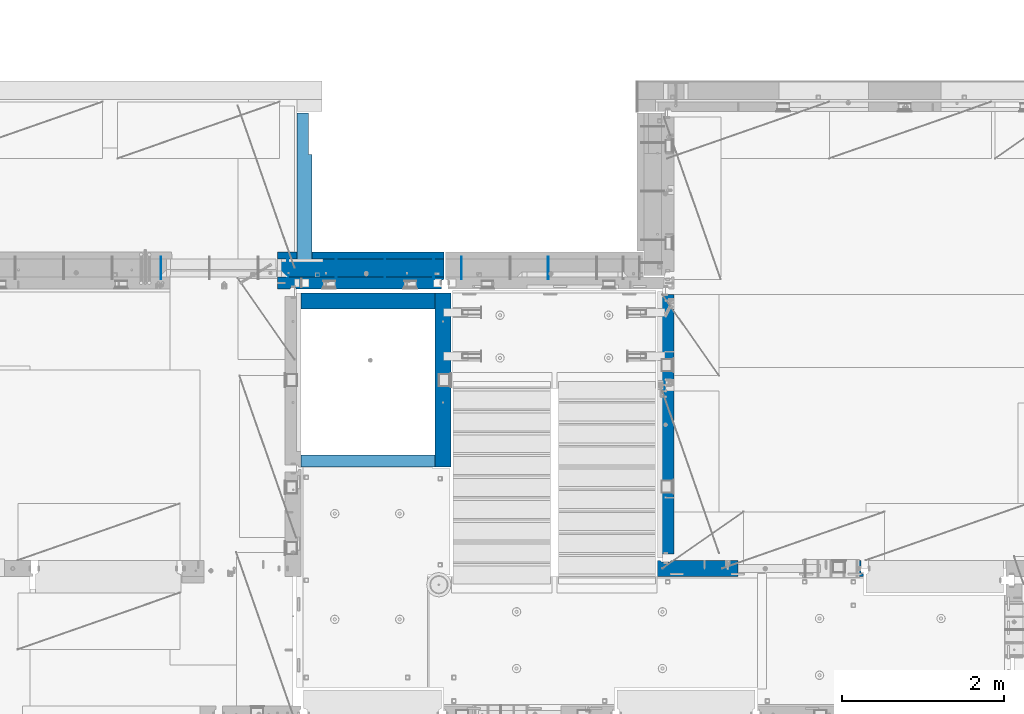
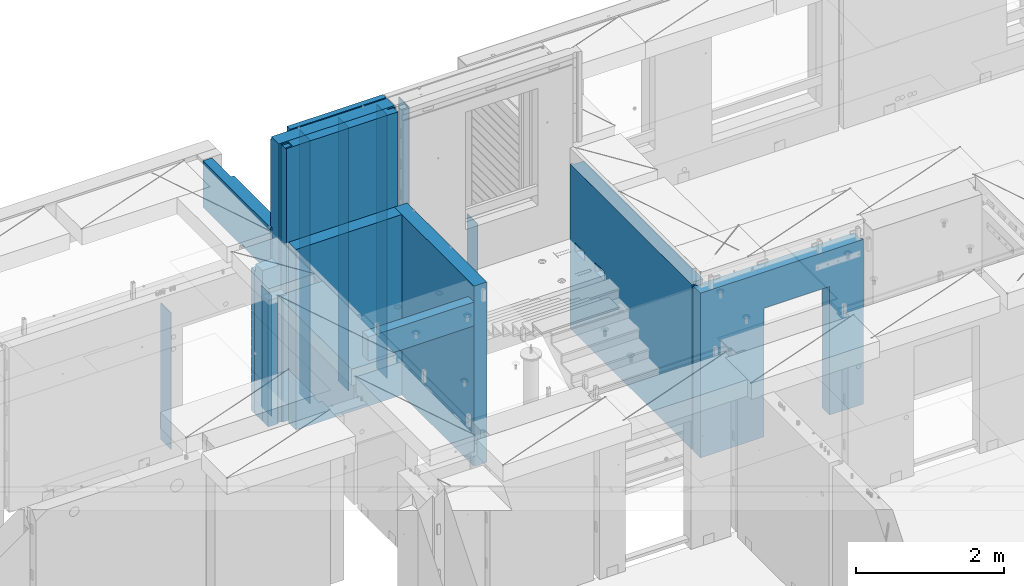
# One storey, part 217 of 325: 16 walls, 8 elements without a shape of their own.
"""IFC2X3 building model written with IfcOpenShell, lengths in millimetres."""

import ifcopenshell
import ifcopenshell.guid

model = None  # the IFC model being written
_history = None  # IfcOwnerHistory: only IFC2X3 demands one
_inside = {}  # id of a spatial element -> (the spatial element, [elements in it])
_under = {}  # id of a project, library or spatial element -> (it, [spatial elements below it])
_declared = {}  # id of a project -> (the project, [libraries it declares])
_typed = {}  # id of a type object -> (the type object, [elements of that type])
_made_of = {}  # id of a material, layer set ... -> (it, [elements and type objects made of it])


def new_model(schema):
    """Start an empty IFC model of exactly this schema.

    Asked for "IFC4X3", IfcOpenShell would pick the latest addendum, in which some entities
    have other attributes; the version numbers below select the first issue.
    IFC2X3 requires an IfcOwnerHistory on every rooted entity: one is made here for all.
    """
    global model, _history
    if schema == "IFC4X3":
        model = ifcopenshell.file(schema_version=(4, 3, 0, 0))
    else:
        model = ifcopenshell.file(schema=schema)
    _inside.clear()
    _under.clear()
    _declared.clear()
    _typed.clear()
    _made_of.clear()
    _history = None
    if model.schema == "IFC2X3":
        org = make("IfcOrganization", Name="unknown")
        user = make(
            "IfcPersonAndOrganization",
            ThePerson=make("IfcPerson", FamilyName="unknown"),
            TheOrganization=org,
        )
        app = make(
            "IfcApplication",
            ApplicationDeveloper=org,
            Version="unknown",
            ApplicationFullName="unknown",
            ApplicationIdentifier="unknown",
        )
        _history = make(
            "IfcOwnerHistory",
            OwningUser=user,
            OwningApplication=app,
            ChangeAction="ADDED",
            CreationDate=0,
        )
    return model


def make(cls, **values):
    """One entity of the class cls with the attributes given. An attribute that is None is left unset."""
    return model.create_entity(
        cls, **{name: value for name, value in values.items() if value is not None}
    )


def rooted(cls, **values):
    """An entity with a GlobalId (a new one), such as an element, a storey or a relation."""
    return make(cls, GlobalId=ifcopenshell.guid.new(), OwnerHistory=_history, **values)


def si_unit(unit_type, name, prefix=None):
    """IfcSIUnit, for example si_unit("LENGTHUNIT", "METRE", prefix="MILLI")."""
    return make("IfcSIUnit", UnitType=unit_type, Prefix=prefix, Name=name)


def assignment(units):
    """IfcUnitAssignment: the units of a project."""
    return None if units is None else make("IfcUnitAssignment", Units=units)


def point(xyz):
    """IfcCartesianPoint."""
    return None if xyz is None else make("IfcCartesianPoint", Coordinates=xyz)


def direction(xyz):
    """IfcDirection."""
    return None if xyz is None else make("IfcDirection", DirectionRatios=xyz)


def frame(location, z_axis=None, x_axis=None):
    """IfcAxis2Placement3D, a coordinate frame: its origin and axes. An axis left out is left unset."""
    return make(
        "IfcAxis2Placement3D",
        Location=point(location),
        Axis=direction(z_axis),
        RefDirection=direction(x_axis),
    )


def origin_with_axes():
    """The frame at (0, 0, 0) with the z axis (0, 0, 1) and the x axis (1, 0, 0) written out."""
    return frame((0.0, 0.0, 0.0), z_axis=(0.0, 0.0, 1.0), x_axis=(1.0, 0.0, 0.0))


def place(relative_to, where):
    """IfcLocalPlacement: puts the frame where relative to a parent placement (None: the world)."""
    return make(
        "IfcLocalPlacement", PlacementRelTo=relative_to, RelativePlacement=where
    )


def context(
    kind, dimensions, precision=None, world=None, true_north=None, identifier=None
):
    """IfcGeometricRepresentationContext, for example the 3D "Model" context."""
    return make(
        "IfcGeometricRepresentationContext",
        ContextIdentifier=identifier,
        ContextType=kind,
        CoordinateSpaceDimension=dimensions,
        Precision=precision,
        WorldCoordinateSystem=world,
        TrueNorth=true_north,
    )


def subcontext(parent, identifier, kind, view, scale=None):
    """IfcGeometricRepresentationSubContext, for example "Body" below "Model"."""
    return make(
        "IfcGeometricRepresentationSubContext",
        ContextIdentifier=identifier,
        ContextType=kind,
        ParentContext=parent,
        TargetScale=scale,
        TargetView=view,
    )


def project(units=None, contexts=None):
    """IfcProject with its units and contexts."""
    return rooted(
        "IfcProject",
        Name="project",
        RepresentationContexts=contexts,
        UnitsInContext=assignment(units),
    )


def spatial(cls, under=None, at=None, **own):
    """A site, building, storey or space (cls), placed at a placement, below another one or the project."""
    s = rooted(cls, ObjectPlacement=at, **own)
    if under is not None:
        _under.setdefault(under.id(), (under, []))[1].append(s)
    return s


def faces_of(points, faces, orient=None, outer=None):
    """IfcFace entities. A face is a list of loops; a loop is a list of indices into points, from 0.

    orient and outer hold one flag for each loop. By default every Orientation is true, the
    first loop of a face is its IfcFaceOuterBound and the others are IfcFaceBound.
    """
    made = []
    for i, loops in enumerate(faces):
        bounds = []
        for j, loop in enumerate(loops):
            is_outer = j == 0 if outer is None else outer[i][j]
            bounds.append(
                make(
                    "IfcFaceOuterBound" if is_outer else "IfcFaceBound",
                    Bound=make("IfcPolyLoop", Polygon=[points[k] for k in loop]),
                    Orientation=True if orient is None else orient[i][j],
                )
            )
        made.append(make("IfcFace", Bounds=bounds))
    return made


def faceted_brep(points, faces, orient=None, outer=None, voids=None):
    """IfcFacetedBrep: a solid bounded by flat faces; with voids (closed shells), ...WithVoids."""
    shared = [point(p) for p in points]
    hull = make("IfcClosedShell", CfsFaces=faces_of(shared, faces, orient, outer))
    if voids is None:
        return make("IfcFacetedBrep", Outer=hull)
    return make(
        "IfcFacetedBrepWithVoids",
        Outer=hull,
        Voids=[
            make(cls, CfsFaces=faces_of(shared, fs, o, b)) for cls, fs, o, b in voids
        ],
    )


def shape(context_of_items, identifier, shape_type, items):
    """IfcShapeRepresentation: the items that make up one representation, for example the "Body"."""
    return make(
        "IfcShapeRepresentation",
        ContextOfItems=context_of_items,
        RepresentationIdentifier=identifier,
        RepresentationType=shape_type,
        Items=items,
    )


def material(Name=None, Category=None):
    """IfcMaterial."""
    return make("IfcMaterial", Name=Name, Category=Category)


def made_of(thing, what):
    """Note that an element or type object is made of a material, layer set ...; save() writes the relation."""
    if what is not None:
        _made_of.setdefault(what.id(), (what, []))[1].append(thing)
    return thing


def type_object(cls, material=None, **own):
    """A type object (cls), such as IfcWallType, which elements share."""
    return made_of(rooted(cls, **own), material)


def element(
    cls,
    number,
    at=None,
    inside=None,
    cuts=None,
    type_object=None,
    material=None,
    context=None,
    identifier="Body",
    shape_type=None,
    held_by="IfcProductDefinitionShape",
    body=None,
    shapes=None,
    **own,
):
    """One element of the class cls, such as IfcWall. Its Tag is "e" and its number.

    at: its placement. inside: the storey or other place that contains it. cuts: it is an
    opening in that element (IfcRelVoidsElement). A single representation is given by context,
    identifier, shape_type and body (its items); several are given by shapes. held_by: the class
    of the entity that holds the representations. save() writes the other relations.
    """
    e = rooted(cls, Tag="e%d" % number, ObjectPlacement=at, **own)
    if body is not None:
        shapes = [shape(context, identifier, shape_type, body)]
    if shapes is not None:
        e.Representation = make(held_by, Representations=shapes)
    if inside is not None:
        _inside.setdefault(inside.id(), (inside, []))[1].append(e)
    if cuts is not None:
        rooted(
            "IfcRelVoidsElement", RelatingBuildingElement=cuts, RelatedOpeningElement=e
        )
    if type_object is not None:
        _typed.setdefault(type_object.id(), (type_object, []))[1].append(e)
    return made_of(e, material)


def aggregate(whole, parts):
    """IfcRelAggregates: a whole, such as a stair, and the parts it consists of."""
    return rooted("IfcRelAggregates", RelatingObject=whole, RelatedObjects=parts)


def save(model, path):
    """Write the relations noted so far, then the file.

    IfcRelAggregates (storeys below a building ...), IfcRelContainedInSpatialStructure (elements
    in a storey), IfcRelDefinesByType, IfcRelAssociatesMaterial and IfcRelDeclares: one each for
    every whole, place, type object, material and project.
    """
    for whole, parts in _under.values():
        aggregate(whole, parts)
    for where, things in _inside.values():
        rooted(
            "IfcRelContainedInSpatialStructure",
            RelatedElements=things,
            RelatingStructure=where,
        )
    for kind, things in _typed.values():
        rooted("IfcRelDefinesByType", RelatedObjects=things, RelatingType=kind)
    for what, things in _made_of.values():
        rooted("IfcRelAssociatesMaterial", RelatedObjects=things, RelatingMaterial=what)
    for by, libraries in _declared.values():
        rooted("IfcRelDeclares", RelatingContext=by, RelatedDefinitions=libraries)
    model.write(path)


model = new_model("IFC2X3")

# Units and contexts
model_context = context("Model", 3, precision=1e-05, world=origin_with_axes())
body_context = subcontext(model_context, "Body", "Model", "MODEL_VIEW")
ifc_project = project(units=[si_unit("LENGTHUNIT", "METRE", prefix="MILLI"), si_unit("AREAUNIT", "SQUARE_METRE"), si_unit("VOLUMEUNIT", "CUBIC_METRE"), si_unit("MASSUNIT", "GRAM", prefix="KILO"), si_unit("TIMEUNIT", "SECOND"), si_unit("PLANEANGLEUNIT", "RADIAN"), si_unit("SOLIDANGLEUNIT", "STERADIAN"), si_unit("THERMODYNAMICTEMPERATUREUNIT", "DEGREE_CELSIUS"), si_unit("LUMINOUSINTENSITYUNIT", "LUMEN")], contexts=[model_context])

# Site, building, storey
site_placement = place(None, origin_with_axes())
site = spatial("IfcSite", under=ifc_project, at=site_placement, CompositionType="ELEMENT")
building_placement = place(site_placement, origin_with_axes())
building = spatial("IfcBuilding", under=site, at=building_placement, CompositionType="ELEMENT")
storey_placement = place(building_placement, origin_with_axes())
storey = spatial("IfcBuildingStorey", under=building, at=storey_placement, Name="1", CompositionType="ELEMENT", Elevation=0.0)

# Assembly, wall
assembly_1_placement = place(storey_placement, origin_with_axes())
assembly_1 = element("IfcElementAssembly", 1, at=assembly_1_placement, inside=storey, AssemblyPlace="NOTDEFINED", PredefinedType="REINFORCEMENT_UNIT")
ifc_material_1 = material(Name="Undefined")
wall_type_1 = type_object("IfcWallType", PredefinedType="NOTDEFINED")
wall_1_placement = place(assembly_1_placement, frame((17645.0002441406, 20550.0, 82810.0), z_axis=(0.0, 0.0, 1.0), x_axis=(0.0, 1.0, 0.0)))
wall_1 = element("IfcWall", 2, at=wall_1_placement, type_object=wall_type_1, material=ifc_material_1, Name="(PD)", context=body_context, shape_type="Brep", body=[
    faceted_brep([(0.0, 5.0, -1000.0), (0.0, 5.0, 1000.0), (280.000000000011, 5.0, 1000.0), (280.000000000011, 5.0, -1000.0), (0.0, -5.0, 1000.0), (280.000000000011, -5.0, 1000.0), (0.0, -5.0, -1000.0), (280.000000000011, -5.0, -1000.0)], [[[0, 1, 2, 3]], [[1, 4, 5, 2]], [[4, 6, 7, 5]], [[6, 0, 3, 7]], [[5, 7, 3, 2]], [[6, 4, 1, 0]]]),
])

assembly_2_placement = place(storey_placement, origin_with_axes())
assembly_2 = element("IfcElementAssembly", 3, at=assembly_2_placement, inside=storey, AssemblyPlace="NOTDEFINED", PredefinedType="REINFORCEMENT_UNIT")
ifc_material_2 = material(Name="CONCRETE/C25/30")
wall_type_2 = type_object("IfcWallType", PredefinedType="NOTDEFINED")
wall_2_placement = place(assembly_2_placement, frame((22310.0, 16980.0, 83112.5), z_axis=(0.0, 0.0, 1.0), x_axis=(1.0, 0.0, 0.0)))
wall_2 = element("IfcWall", 4, at=wall_2_placement, type_object=wall_type_2, material=ifc_material_2, context=body_context, shape_type="Brep", body=[
    faceted_brep([(890.000686645508, 100.0, 762.5), (890.000686645508, -100.0, 762.5), (890.000686645508, -100.0, -1357.5), (890.000686645508, 100.0, -1357.5), (1910.00068664551, 100.0, 762.5), (1910.00068664551, -100.0, 762.5), (1910.00068664551, 100.0, -1357.5), (1910.00068664551, -100.0, -1357.5), (-100.0, -100.0, -1357.5), (-100.0, -100.0, 1357.5), (-100.0, 100.0, 1357.5), (-100.0, 100.0, -1357.5), (2440.0, -100.0, 1357.5), (2440.0, -100.0, -1357.5), (2440.0, -70.0000000000036, -1357.5), (2440.0, -70.0000000000036, 1357.5), (2410.0, 100.0, 1357.5), (2410.0, -57.0, 1357.5), (2410.0, -57.0, -1357.5), (2410.0, 100.0, -1357.5), (65.0000000000036, 100.0, 1357.5), (52.0, 80.0, 1357.5), (-52.0, 80.0, 1357.5), (-65.0, 100.0, 1357.5), (-65.0, 100.0, -1357.5), (-52.0, 80.0, -1357.5), (52.0, 80.0, -1357.5), (65.0000000000036, 100.0, -1357.5)], [[[0, 1, 2, 3]], [[4, 5, 1, 0]], [[6, 7, 5, 4]], [[8, 9, 10, 11]], [[12, 13, 14, 15]], [[16, 17, 18, 19]], [[15, 14, 18, 17]], [[16, 20, 21, 22, 23, 10, 9, 12, 15, 17]], [[11, 10, 23, 24]], [[22, 25, 24, 23]], [[21, 26, 25, 22]], [[20, 27, 26, 21]], [[8, 11, 24, 25, 26, 27, 3, 2]], [[13, 12, 9, 8, 2, 1, 5, 7]], [[19, 18, 14, 13, 7, 6]], [[3, 27, 20, 16, 19, 6, 4, 0]]]),
])
aggregate(assembly_2, [wall_2])

assembly_3_placement = place(storey_placement, origin_with_axes())
assembly_3 = element("IfcElementAssembly", 5, at=assembly_3_placement, inside=storey, AssemblyPlace="NOTDEFINED", PredefinedType="REINFORCEMENT_UNIT")
wall_3_placement = place(assembly_3_placement, frame((22310.0, 16980.0, 83112.5), z_axis=(0.0, 0.0, 1.0), x_axis=(0.0, 1.0, 0.0)))
wall_3 = element("IfcWall", 6, at=wall_3_placement, type_object=wall_type_2, material=ifc_material_2, context=body_context, shape_type="Brep", body=[
    faceted_brep([(3059.9952678883, 0.0998642726626713, 102.5), (3259.9952678883, 0.0998642726626713, 102.5), (3259.9952678883, 0.0998642726626713, -7.5), (3059.9952678883, 0.0998642726626713, -7.5), (3034.9952678883, 100.099864272663, -7.5), (3284.9952678883, 100.099864272663, -7.5), (3034.9952678883, 100.099864272663, 137.5), (3284.9952678883, 100.099864272663, 137.5), (3420.0, 70.0, 1357.5), (3420.0, 100.0, 1357.5), (130.0, 100.0, 1357.5), (130.0, 70.0, 1357.5), (180.0, 57.0, 1357.5), (180.0, -100.0, 1357.5), (3384.99999178648, -100.000000948603, 1357.5), (3385.00000172571, 57.0000007519884, 1357.5), (130.0, 100.0, -1357.5), (130.0, 70.0, -1357.5), (180.0, 57.0, -1357.5), (180.0, -100.0, -1357.5), (3384.99999178648, -100.0, -1357.5), (3385.00000172571, 57.0000007519884, -1357.5), (3420.0, 100.0, -1357.5), (3420.0, 70.0, -1357.5), (2519.9952678883, 0.0998642726626713, 102.5), (2719.9952678883, 0.0998642726626713, 102.5), (2719.9952678883, 0.0998642726626713, -7.5), (2519.9952678883, 0.0998642726626713, -7.5), (2744.9952678883, 100.099864272663, -7.5), (2744.9952678883, 100.099864272663, 137.5), (2494.9952678883, 100.099864272663, -7.5), (2494.9952678883, 100.099864272663, 137.5)], [[[0, 1, 2, 3]], [[4, 3, 2, 5]], [[6, 0, 3, 4]], [[7, 1, 0, 6]], [[5, 2, 1, 7]], [[8, 9, 10, 11, 12, 13, 14, 15]], [[10, 16, 17, 11]], [[11, 17, 18, 12]], [[13, 12, 18, 19]], [[13, 19, 20, 14]], [[14, 20, 21, 15]], [[19, 18, 17, 16, 22, 23, 21, 20]], [[15, 21, 23, 8]], [[22, 9, 8, 23]], [[24, 25, 26, 27]], [[28, 26, 25, 29]], [[30, 27, 26, 28]], [[31, 24, 27, 30]], [[29, 25, 24, 31]], [[16, 10, 9, 22], [4, 5, 7, 6], [30, 28, 29, 31]]]),
])
aggregate(assembly_3, [wall_3])

# Assembly, walls
assembly_4_placement = place(storey_placement, origin_with_axes())
assembly_4 = element("IfcElementAssembly", 7, at=assembly_4_placement, inside=storey, AssemblyPlace="NOTDEFINED", PredefinedType="REINFORCEMENT_UNIT")
wall_type_3 = type_object("IfcWallType", PredefinedType="NOTDEFINED")
wall_4_placement = place(assembly_4_placement, frame((17809.9999105288, 20280.0000293051, 83242.5), z_axis=(0.0, 0.0, 1.0), x_axis=(1.0, 0.0, 0.0)))
wall_4 = element("IfcWall", 8, at=wall_4_placement, type_object=wall_type_3, material=ifc_material_2, context=body_context, shape_type="Brep", body=[
    faceted_brep([(0.0, 100.0, -1487.5), (0.0, 100.0, 1487.5), (1649.99977111816, 100.0, 1487.5), (1649.99977111816, 100.0, -1487.5), (0.0, -100.0, 1487.5), (1649.99977111816, -100.0, 1487.5), (0.0, -100.0, -1487.5), (1649.99977111816, -100.0, -1487.5)], [[[0, 1, 2, 3]], [[1, 4, 5, 2]], [[4, 6, 7, 5]], [[6, 0, 3, 7]], [[5, 7, 3, 2]], [[6, 4, 1, 0]]]),
])
wall_5_placement = place(assembly_4_placement, frame((19559.999681647, 18229.9992663657, 83242.5), z_axis=(0.0, 0.0, 1.0), x_axis=(0.0, 1.0, 0.0)))
wall_5 = element("IfcWall", 9, at=wall_5_placement, type_object=wall_type_3, material=ifc_material_2, context=body_context, shape_type="Brep", body=[
    faceted_brep([(1470.00546574604, -0.100182625668822, -27.5), (1270.00546574604, -0.100182625668822, -27.5), (1270.00546574604, -0.100182625668822, -137.5), (1470.00546574604, -0.100182625668822, -137.5), (1245.00546574604, -100.100182625669, -137.5), (1245.00546574604, -100.100182625669, 7.5), (1495.00546574604, -100.100182625669, -137.5), (1495.00546574604, -100.100182625669, 7.5), (0.0, -100.0, -1487.5), (0.0, 100.0, -1487.5), (2150.00073363433, 100.0, -1487.5), (2150.00073363433, -100.0, -1487.5), (0.0, -100.0, 1487.5), (0.0, 100.0, 1487.5), (2150.00073363433, -100.0, 1487.5), (2150.00073363433, 100.0, 1487.5), (2010.00546574604, -0.100182625668822, -27.5), (1810.00546574604, -0.100182625668822, -27.5), (1810.00546574604, -0.100182625668822, -137.5), (2010.00546574604, -0.100182625668822, -137.5), (1785.00546574604, -100.100182625669, 7.5), (2035.00546574604, -100.100182625669, 7.5), (1785.00546574604, -100.100182625669, -137.5), (2035.00546574604, -100.100182625669, -137.5)], [[[0, 1, 2, 3]], [[4, 2, 1, 5]], [[6, 3, 2, 4]], [[7, 0, 3, 6]], [[5, 1, 0, 7]], [[8, 9, 10, 11]], [[8, 12, 13, 9]], [[13, 12, 14, 15]], [[9, 13, 15, 10]], [[14, 11, 10, 15]], [[16, 17, 18, 19]], [[20, 17, 16, 21]], [[22, 18, 17, 20]], [[23, 19, 18, 22]], [[21, 16, 19, 23]], [[12, 8, 11, 14], [4, 5, 7, 6], [22, 20, 21, 23]]]),
])
wall_type_4 = type_object("IfcWallType", PredefinedType="NOTDEFINED")
wall_6_placement = place(assembly_4_placement, frame((17809.9999105288, 18304.9992663657, 84272.5), z_axis=(0.0, 0.0, 1.0), x_axis=(1.0, 0.0, 0.0)))
wall_6 = element("IfcWall", 10, at=wall_6_placement, type_object=wall_type_4, material=ifc_material_2, context=body_context, shape_type="Brep", body=[
    faceted_brep([(0.0, 75.0, -197.5), (0.0, 75.0, 197.5), (1649.99961853027, 75.0, 197.5), (1649.99961853027, 75.0, -197.5), (0.0, -75.0, 197.5), (1649.99961853027, -75.0, 197.5), (0.0, -75.0, -197.5), (1649.99961853027, -75.0, -197.5)], [[[0, 1, 2, 3]], [[1, 4, 5, 2]], [[4, 6, 7, 5]], [[6, 0, 3, 7]], [[5, 7, 3, 2]], [[6, 4, 1, 0]]]),
])
aggregate(assembly_4, [wall_4, wall_6, wall_5])

assembly_5_placement = place(storey_placement, origin_with_axes())
assembly_5 = element("IfcElementAssembly", 11, at=assembly_5_placement, inside=storey, AssemblyPlace="NOTDEFINED", PredefinedType="REINFORCEMENT_UNIT")
wall_type_5 = type_object("IfcWallType", PredefinedType="NOTDEFINED")
wall_7_placement = place(assembly_5_placement, frame((20860.0002441406, 20550.0, 82835.0), z_axis=(0.0, 0.0, 1.0), x_axis=(0.0, 1.0, 0.0)))
wall_7 = element("IfcWall", 12, at=wall_7_placement, type_object=wall_type_5, material=ifc_material_1, Name="(PD)", context=body_context, shape_type="Brep", body=[
    faceted_brep([(0.0, 5.0, -1025.0), (0.0, 5.0, 1025.0), (280.0, 5.0, 1025.0), (280.0, 5.0, -1025.0), (0.0, -5.0, 1025.0), (280.0, -5.0, 1025.0), (0.0, -5.0, -1025.0), (280.0, -5.0, -1025.0)], [[[0, 1, 2, 3]], [[1, 4, 5, 2]], [[4, 6, 7, 5]], [[6, 0, 3, 7]], [[5, 7, 3, 2]], [[6, 4, 1, 0]]]),
])
wall_type_6 = type_object("IfcWallType", PredefinedType="NOTDEFINED")
wall_8_placement = place(assembly_5_placement, frame((19790.0002441406, 20550.0, 83985.0), z_axis=(0.0, 0.0, 1.0), x_axis=(0.0, 1.0, 0.0)))
wall_8 = element("IfcWall", 13, at=wall_8_placement, type_object=wall_type_6, material=ifc_material_1, Name="(PD)", context=body_context, shape_type="Brep", body=[
    faceted_brep([(0.0, 5.0, -2175.0), (0.0, 5.0, 2175.0), (280.0, 5.0, 2175.0), (280.0, 5.0, -2175.0), (0.0, -5.0, 2175.0), (280.0, -5.0, 2175.0), (0.0, -5.0, -2175.0), (280.0, -5.0, -2175.0)], [[[0, 1, 2, 3]], [[1, 4, 5, 2]], [[4, 6, 7, 5]], [[6, 0, 3, 7]], [[5, 7, 3, 2]], [[6, 4, 1, 0]]]),
])
aggregate(assembly_5, [wall_7, wall_8])

# Wall
wall_9_placement = place(assembly_1_placement, frame((18245.0002441406, 20550.0, 83985.0), z_axis=(0.0, 0.0, 1.0), x_axis=(0.0, 1.0, 0.0)))
wall_9 = element("IfcWall", 14, at=wall_9_placement, type_object=wall_type_6, material=ifc_material_1, Name="(PD)", context=body_context, shape_type="Brep", body=[
    faceted_brep([(0.0, 5.0, -2175.0), (0.0, 5.0, 2175.0), (280.0, 5.0, 2175.0), (280.0, 5.0, -2175.0), (0.0, -5.0, 2175.0), (280.0, -5.0, 2175.0), (0.0, -5.0, -2175.0), (280.0, -5.0, -2175.0)], [[[0, 1, 2, 3]], [[1, 4, 5, 2]], [[4, 6, 7, 5]], [[6, 0, 3, 7]], [[5, 7, 3, 2]], [[6, 4, 1, 0]]]),
])

wall_10_placement = place(assembly_1_placement, frame((18845.0002441406, 20550.0, 83985.0), z_axis=(0.0, 0.0, 1.0), x_axis=(0.0, 1.0, 0.0)))
wall_10 = element("IfcWall", 15, at=wall_10_placement, type_object=wall_type_6, material=ifc_material_1, Name="(PD)", context=body_context, shape_type="Brep", body=[
    faceted_brep([(0.0, 5.0, -2175.0), (0.0, 5.0, 2175.0), (280.0, 5.0, 2175.0), (280.0, 5.0, -2175.0), (0.0, -5.0, 2175.0), (280.0, -5.0, 2175.0), (0.0, -5.0, -2175.0), (280.0, -5.0, -2175.0)], [[[0, 1, 2, 3]], [[1, 4, 5, 2]], [[4, 6, 7, 5]], [[6, 0, 3, 7]], [[5, 7, 3, 2]], [[6, 4, 1, 0]]]),
])

wall_11_placement = place(assembly_1_placement, frame((19445.0002441406, 20550.0, 83985.0), z_axis=(0.0, 0.0, 1.0), x_axis=(0.0, 1.0, 0.0)))
wall_11 = element("IfcWall", 16, at=wall_11_placement, type_object=wall_type_6, material=ifc_material_1, Name="(PD)", context=body_context, shape_type="Brep", body=[
    faceted_brep([(0.0, 5.0, -2175.0), (0.0, 5.0, 2175.0), (280.0, 5.0, 2175.0), (280.0, 5.0, -2175.0), (0.0, -5.0, 2175.0), (280.0, -5.0, 2175.0), (0.0, -5.0, -2175.0), (280.0, -5.0, -2175.0)], [[[0, 1, 2, 3]], [[1, 4, 5, 2]], [[4, 6, 7, 5]], [[6, 0, 3, 7]], [[5, 7, 3, 2]], [[6, 4, 1, 0]]]),
])

# Assembly, wall
assembly_6_placement = place(storey_placement, origin_with_axes())
assembly_6 = element("IfcElementAssembly", 17, at=assembly_6_placement, inside=storey, AssemblyPlace="NOTDEFINED", PredefinedType="REINFORCEMENT_UNIT")
wall_type_7 = type_object("IfcWallType", PredefinedType="NOTDEFINED")
wall_12_placement = place(assembly_6_placement, frame((16080.0002441406, 20549.9951872276, 82940.0), z_axis=(0.0, 0.0, 1.0), x_axis=(0.0, 1.0, 0.0)))
wall_12 = element("IfcWall", 18, at=wall_12_placement, type_object=wall_type_7, material=ifc_material_1, Name="(PD)", context=body_context, shape_type="Brep", body=[
    faceted_brep([(0.0, 5.0, -1125.0), (0.0, 5.0, 1125.0), (280.0, 5.0, 1125.0), (280.0, 5.0, -1125.0), (0.0, -5.0, 1125.0), (280.0, -5.0, 1125.0), (0.0, -5.0, -1125.0), (280.0, -5.0, -1125.0)], [[[0, 1, 2, 3]], [[1, 4, 5, 2]], [[4, 6, 7, 5]], [[6, 0, 3, 7]], [[5, 7, 3, 2]], [[6, 4, 1, 0]]]),
])
aggregate(assembly_6, [wall_12])

assembly_7_placement = place(storey_placement, origin_with_axes())
assembly_7 = element("IfcElementAssembly", 19, at=assembly_7_placement, inside=storey, Name="Steel Assembly", AssemblyPlace="NOTDEFINED", PredefinedType="NOTDEFINED")
ifc_material_3 = material()
wall_type_8 = type_object("IfcWallType", PredefinedType="NOTDEFINED")
wall_13_placement = place(assembly_7_placement, frame((17852.4997805463, 20784.9964685314, 84357.5), z_axis=(0.0, 0.0, 1.0), x_axis=(0.0, 1.0, 0.0)))
wall_13 = element("IfcWall", 20, at=wall_13_placement, type_object=wall_type_8, material=ifc_material_3, context=body_context, shape_type="Brep", body=[
    faceted_brep([(1820.00352031536, -47.4999962314287, 382.5), (1305.00353754246, -47.5000585464295, 382.5), (1305.00353754246, -47.5000585464295, -382.5), (1820.00352031536, -47.4999962314287, -382.5), (1305.00354298746, -92.5000585464295, 382.5), (1305.00354298746, -92.5, -382.5), (3.63797880709171e-12, 92.5, 382.5), (1820.00352031536, 92.5, 382.5), (1820.00352031536, 92.5, -382.5), (115.003522946692, 92.5, -382.5), (115.003522655803, 92.5000018150822, -237.5), (3.63797880709171e-12, 92.5, -237.500000230008), (115.003525615804, -92.5, -237.5), (115.003525906694, -92.5, -382.5), (3.63797880709171e-12, -92.5, -237.500000230008), (3.63797880709171e-12, -92.5, 382.5)], [[[0, 1, 2, 3]], [[4, 5, 2, 1]], [[6, 7, 8, 9, 10, 11]], [[12, 10, 9, 13]], [[14, 11, 10, 12]], [[15, 6, 11, 14]], [[0, 7, 6, 15, 4, 1]], [[8, 7, 0, 3]], [[13, 9, 8, 3, 2, 5]], [[15, 14, 12, 13, 5, 4]]]),
])
aggregate(assembly_7, [wall_13])

# Wall
ifc_material_4 = material(Name="CONCRETE/C30/37")
wall_type_9 = type_object("IfcWallType", PredefinedType="NOTDEFINED")
wall_14_placement = place(assembly_1_placement, frame((17520.0, 20842.5, 83997.5), z_axis=(0.0, 0.0, 1.0), x_axis=(1.0, 0.0, 0.0)))
wall_14 = element("IfcWall", 21, at=wall_14_placement, type_object=wall_type_9, material=ifc_material_4, context=body_context, shape_type="Brep", body=[
    faceted_brep([(2055.0, 42.4999992873272, -7.00000005522452), (0.0, 42.5, -7.00000005523907), (0.0, 32.4999992507037, -5.00000000074215), (2055.0, 32.4999992517696, -5.00000000074215), (0.0, 32.4999991127006, 5.0000004004396), (2055.0, 32.4999991137702, 5.00000040045416), (2055.0, 42.4999992442426, 6.99999988925993), (0.0, 42.5, 6.99999988924537), (0.0, 42.5, 107.5), (0.0, -42.5, 107.5), (559.999996998125, -42.5, 107.5), (559.999996998125, 42.4999990696306, 107.5), (2055.0, 42.4999992442426, -143.00000011074), (2055.0, 32.4999991137702, -144.999999599546), (3.63797880709171e-12, 32.4999991127006, -144.99999959956), (0.0, 42.5, -143.000000110755), (2055.0, 32.4999992517696, -155.000000000742), (3.63797880709171e-12, 32.4999992507037, -155.000000000742), (2055.0, 42.499999284275, -157.000000055225), (0.0, 42.5, -157.000000055239), (2055.0, 42.4999992437079, -293.000000110769), (0.0, 42.5, -293.000000110755), (2055.0, 32.499999113239, -294.999999599575), (0.0, 32.4999991127006, -294.99999959956), (2055.0, 32.4999992512385, -305.000000000771), (0.0, 32.4999992507037, -305.000000000742), (2055.0, 42.4999992814846, -307.000000055254), (0.0, 42.5, -307.000000055239), (2055.0, 42.4999992431549, -443.00000011074), (0.0, 42.5, -443.000000110755), (2055.0, 32.4999991126861, -444.99999959956), (0.0, 32.4999991127006, -444.99999959956), (2055.0, 32.4999992506928, -455.000000000771), (0.0, 32.4999992507037, -455.000000000742), (2055.0, 42.499999278949, -457.000000055225), (0.0, 42.5, -457.000000055239), (2055.0, 42.4999992426237, -593.000000110755), (0.0, 42.5, -593.000000110755), (2055.0, 32.4999991121585, -594.999999599575), (3.63797880709171e-12, 32.4999991127006, -594.99999959956), (2055.0, 32.4999992501653, -605.000000000786), (3.63797880709171e-12, 32.4999992507037, -605.000000000742), (2055.0, 42.5, -607.000000055239), (0.0, 42.5, -607.000000055239), (2055.0, 42.4999992426237, -743.000000110755), (0.0, 42.5, -743.000000110755), (2055.0, 32.4999991121585, -744.999999599575), (0.0, 32.4999991127006, -744.99999959956), (2055.0, 32.4999992501653, -755.000000000786), (0.0, 32.4999992507037, -755.000000000742), (2055.0, 42.5, -757.000000055239), (0.0, 42.5, -757.000000055239), (2055.0, 42.4999992426237, -893.000000110755), (0.0, 42.5, -893.000000110755), (2055.0, 32.4999991121585, -894.999999599575), (0.0, 32.4999991127006, -894.99999959956), (2055.0, 32.4999992501653, -905.000000000786), (0.0, 32.4999992507037, -905.000000000742), (2055.0, 42.5, -907.000000055239), (0.0, 42.5, -907.000000055239), (2055.0, 42.4999992426237, -1043.00000011075), (0.0, 42.5, -1043.00000011075), (2055.0, 32.4999991121585, -1044.99999959957), (0.0, 32.4999991127006, -1044.99999959956), (2055.0, 32.4999992501653, -1055.00000000079), (0.0, 32.4999992507037, -1055.00000000074), (2055.0, 42.5, -1057.00000005524), (0.0, 42.5, -1057.00000005524), (2055.0, 42.4999992426237, -1193.00000011075), (0.0, 42.5, -1193.00000011075), (2055.0, 32.4999991121585, -1194.99999959957), (0.0, 32.4999991127006, -1194.99999959956), (2055.0, 32.4999992501653, -1205.00000000079), (0.0, 32.4999992507037, -1205.00000000074), (2055.0, 42.5, -1207.00000005524), (0.0, 42.5, -1207.00000005524), (2055.0, 42.4999992426237, -1343.00000011075), (0.0, 42.5, -1343.00000011075), (2055.0, 32.4999991121585, -1344.99999959957), (0.0, 32.4999991127006, -1344.99999959956), (2055.0, 32.4999992501653, -1355.00000000079), (0.0, 32.4999992507037, -1355.00000000074), (2055.0, 42.5, -1357.00000005524), (0.0, 42.5, -1357.00000005524), (2055.0, 42.4999992426237, -1493.00000011075), (0.0, 42.5, -1493.00000011075), (2055.0, 32.4999991121585, -1494.99999959957), (3.63797880709171e-12, 32.499999114305, -1494.99999959956), (2055.0, 32.4999992501653, -1505.00000000079), (3.63797880709171e-12, 32.4999992523044, -1505.00000000077), (2055.0, 42.5, -1507.00000005524), (0.0, 42.5, -1507.00000005524), (2055.0, 42.4999992426237, -1643.00000011075), (0.0, 42.5, -1643.00000011074), (2055.0, 32.4999991121585, -1644.99999959957), (0.0, 32.4999991137702, -1644.99999959955), (2055.0, 32.4999992501653, -1655.00000000079), (0.0, 32.4999992517696, -1655.00000000074), (2055.0, 42.5, -1657.00000005524), (0.0, 42.5, -1657.00000005522), (2055.0, 42.4999992426237, -1793.00000011075), (0.0, 42.5, -1793.00000011077), (2055.0, 32.4999991121585, -1794.99999959957), (0.0, 32.499999113239, -1794.99999959957), (2055.0, 32.4999992501653, -1805.00000000079), (0.0, 32.4999992512385, -1805.00000000077), (2055.0, 42.5, -1807.00000005524), (0.0, 42.5, -1807.00000005525), (2055.0, 42.4999992426237, -1943.00000011075), (0.0, 42.5, -1943.00000011074), (2055.0, 32.4999991121585, -1944.99999959957), (0.0, 32.4999991126861, -1944.99999959956), (2055.0, 32.4999992501653, -1955.00000000079), (0.0, 32.4999992506928, -1955.00000000077), (2055.0, 42.5, -1957.00000005524), (0.0, 42.5, -1957.00000005522), (2055.0, 42.4999992426237, -2093.00000011075), (0.0, 42.5, -2093.00000011075), (2055.0, 32.4999991121585, -2094.99999959957), (0.0, 32.4999991121585, -2094.99999959957), (2055.0, 32.4999992501653, -2105.00000000079), (0.0, 32.4999992501653, -2105.00000000079), (2055.0, 42.5, -2107.00000005524), (0.0, 42.5, -2107.00000005524), (2055.0, 42.5, -2242.5), (0.0, 42.5, -2242.5), (0.0, -42.5, -2242.5), (2055.0, -42.5, -2242.5), (2055.0, 32.4999991148361, 155.00000040044), (2055.0, 32.4999992528356, 144.999999999214), (560.0, 32.4999992528356, 144.999999999214), (560.0, 32.4999991148361, 155.00000040044), (2055.0, 42.4999992453049, 156.99999988926), (560.0, 42.4999992453049, 156.99999988926), (2055.0, 42.4999992945195, 292.999999944761), (560.0, 42.4999992707017, 292.999999944761), (2055.0, 32.4999992533558, 294.9999999992), (560.0, 32.4999992533558, 294.9999999992), (2055.0, 32.49999911536, 305.000000400425), (560.0, 32.49999911536, 305.000000400425), (2055.0, 42.4999992458288, 306.999999889245), (560.0, 42.4999992458288, 306.999999889245), (2055.0, 42.4999992988232, 442.999999944761), (560.0, 42.4999992712328, 442.999999944761), (2055.0, 32.4999992538869, 444.9999999992), (560.0, 32.4999992538869, 444.9999999992), (2055.0, 32.4999991158911, 455.000000400425), (560.0, 32.4999991158911, 455.000000400425), (2055.0, 42.4999992463599, 456.999999889245), (560.0, 42.4999992463599, 456.999999889245), (2055.0, 42.4999993037636, 592.999999944732), (560.0, 42.4999992717676, 592.999999944732), (2055.0, 32.4999992544217, 594.999999999185), (560.0, 32.4999992544217, 594.999999999185), (2055.0, 32.4999991164259, 605.000000400396), (560.0, 32.4999991164259, 605.000000400396), (2055.0, 42.4999992468947, 606.999999889216), (560.0, 42.4999992468947, 606.999999889216), (2055.0, 42.4999993095189, 742.999999944761), (560.0, 42.4999992673911, 742.999999944761), (2055.0, 32.4999992500452, 744.9999999992), (560.0, 32.4999992500452, 744.9999999992), (2055.0, 32.4999991120385, 755.000000400425), (560.0, 32.4999991120385, 755.000000400425), (2055.0, 42.4999992425073, 756.999999889245), (560.0, 42.4999992425073, 756.999999889245), (2055.0, 42.4999993118581, 892.999999944761), (560.0, 42.4999992673838, 892.999999944761), (2055.0, 32.4999992500379, 894.9999999992), (560.0, 32.4999992500379, 894.9999999992), (2055.0, 32.4999991120312, 905.000000400425), (560.0, 32.4999991120312, 905.000000400425), (2055.0, 42.4999992425001, 906.999999889245), (560.0, 42.4999992425001, 906.999999889245), (2055.0, 42.4999993196398, 1042.99999994476), (560.0, 42.4999992673729, 1042.99999994476), (2055.0, 32.4999992500307, 1044.99999999921), (560.0, 32.4999992500307, 1044.99999999921), (2055.0, 32.4999991120349, 1055.00000040044), (560.0, 32.4999991120349, 1055.00000040044), (2055.0, 42.4999992425073, 1056.99999988925), (560.0, 42.4999992425073, 1056.99999988925), (2055.0, 42.4999993294077, 1192.99999994478), (560.0, 42.499999267362, 1192.99999994478), (2055.0, 32.4999992500161, 1194.99999999921), (560.0, 32.4999992500161, 1194.99999999921), (2055.0, 32.499999112013, 1205.00000040044), (560.0, 32.499999112013, 1205.00000040044), (2055.0, 42.4999992424782, 1206.99999988926), (560.0, 42.4999992424782, 1206.99999988926), (2055.0, 42.4999993419697, 1342.99999994475), (560.0, 42.4999992673402, 1342.99999994475), (2055.0, 32.4999992499979, 1344.9999999992), (560.0, 32.4999992499979, 1344.9999999992), (2055.0, 32.4999991120058, 1355.00000040043), (560.0, 32.4999991120058, 1355.00000040043), (2055.0, 42.4999992424746, 1356.99999988923), (560.0, 42.4999992424746, 1356.99999988923), (2055.0, 42.4999993588208, 1492.99999994475), (560.0, 42.4999992673256, 1492.99999994475), (2055.0, 32.4999992499797, 1494.99999999919), (560.0, 32.4999992499797, 1494.99999999919), (2055.0, 32.499999111973, 1505.00000040041), (560.0, 32.499999111973, 1505.00000040041), (2055.0, 42.4999992424418, 1506.99999988923), (560.0, 42.4999992424418, 1506.99999988923), (2055.0, 42.4999993825222, 1642.99999994476), (560.0, 42.4999992673147, 1642.99999994476), (2055.0, 32.4999992499688, 1644.9999999992), (560.0, 32.4999992499688, 1644.9999999992), (2055.0, 32.4999991119657, 1655.00000040043), (560.0, 32.4999991119657, 1655.00000040043), (2055.0, 42.4999992424309, 1656.99999988925), (560.0, 42.4999992424309, 1656.99999988925), (2055.0, 42.4999994184, 1792.99999994476), (560.0, 42.4999992673074, 1792.99999994476), (2055.0, 32.4999992499652, 1794.99999999921), (560.0, 32.4999992499652, 1794.99999999921), (2055.0, 32.4999991119694, 1805.00000040044), (560.0, 32.4999991119694, 1805.00000040044), (2055.0, 42.4999992424418, 1806.99999988925), (560.0, 42.4999992424418, 1806.99999988925), (2055.0, 42.499999479016, 1942.99999994478), (560.0, 42.4999992672929, 1942.99999994478), (2055.0, 32.499999249947, 1944.99999999921), (560.0, 32.499999249947, 1944.99999999921), (2055.0, 32.4999991119439, 1955.00000040044), (560.0, 32.4999991119439, 1955.00000040044), (2055.0, 42.4999992424127, 1956.99999988926), (560.0, 42.4999992424127, 1956.99999988926), (2055.0, 42.4999996032966, 2092.99999994476), (560.0, 42.4999992672783, 2092.99999994476), (2055.0, 32.4999992499324, 2094.9999999992), (560.0, 32.4999992499324, 2094.9999999992), (2055.0, 32.4999991119257, 2105.00000040043), (560.0, 32.4999991119257, 2105.00000040043), (2055.0, 42.4999992423946, 2106.99999988925), (560.0, 42.4999992423946, 2106.99999988925), (2055.0, 42.5, 2242.5), (560.0, 42.5, 2242.5), (2055.0, -42.5, 2242.5), (560.0, -42.5, 2242.5), (560.0, 42.4999992701814, 142.999999944775), (2055.0, 42.4999993348501, 142.999999944775)], [[[0, 1, 2, 3]], [[3, 2, 4, 5]], [[6, 5, 4, 7]], [[8, 9, 10, 11]], [[12, 13, 14, 15]], [[16, 17, 14, 13]], [[18, 19, 17, 16]], [[20, 21, 19, 18]], [[20, 22, 23, 21]], [[24, 25, 23, 22]], [[26, 27, 25, 24]], [[28, 29, 27, 26]], [[28, 30, 31, 29]], [[32, 33, 31, 30]], [[34, 35, 33, 32]], [[36, 37, 35, 34]], [[36, 38, 39, 37]], [[40, 41, 39, 38]], [[42, 43, 41, 40]], [[43, 42, 44, 45]], [[44, 46, 47, 45]], [[48, 49, 47, 46]], [[50, 51, 49, 48]], [[51, 50, 52, 53]], [[52, 54, 55, 53]], [[56, 57, 55, 54]], [[58, 59, 57, 56]], [[59, 58, 60, 61]], [[60, 62, 63, 61]], [[64, 65, 63, 62]], [[66, 67, 65, 64]], [[67, 66, 68, 69]], [[68, 70, 71, 69]], [[72, 73, 71, 70]], [[74, 75, 73, 72]], [[75, 74, 76, 77]], [[76, 78, 79, 77]], [[80, 81, 79, 78]], [[82, 83, 81, 80]], [[83, 82, 84, 85]], [[84, 86, 87, 85]], [[88, 89, 87, 86]], [[90, 91, 89, 88]], [[91, 90, 92, 93]], [[92, 94, 95, 93]], [[96, 97, 95, 94]], [[98, 99, 97, 96]], [[99, 98, 100, 101]], [[100, 102, 103, 101]], [[104, 105, 103, 102]], [[106, 107, 105, 104]], [[107, 106, 108, 109]], [[108, 110, 111, 109]], [[112, 113, 111, 110]], [[114, 115, 113, 112]], [[115, 114, 116, 117]], [[116, 118, 119, 117]], [[120, 121, 119, 118]], [[122, 123, 121, 120]], [[124, 125, 123, 122]], [[126, 125, 124, 127]], [[128, 129, 130, 131]], [[132, 128, 131, 133]], [[134, 132, 133, 135]], [[136, 134, 135, 137]], [[138, 136, 137, 139]], [[140, 138, 139, 141]], [[142, 140, 141, 143]], [[144, 142, 143, 145]], [[146, 144, 145, 147]], [[148, 146, 147, 149]], [[150, 148, 149, 151]], [[152, 150, 151, 153]], [[154, 152, 153, 155]], [[156, 154, 155, 157]], [[158, 156, 157, 159]], [[160, 158, 159, 161]], [[162, 160, 161, 163]], [[164, 162, 163, 165]], [[166, 164, 165, 167]], [[168, 166, 167, 169]], [[170, 168, 169, 171]], [[172, 170, 171, 173]], [[174, 172, 173, 175]], [[176, 174, 175, 177]], [[178, 176, 177, 179]], [[180, 178, 179, 181]], [[182, 180, 181, 183]], [[184, 182, 183, 185]], [[186, 184, 185, 187]], [[188, 186, 187, 189]], [[190, 188, 189, 191]], [[192, 190, 191, 193]], [[194, 192, 193, 195]], [[196, 194, 195, 197]], [[198, 196, 197, 199]], [[200, 198, 199, 201]], [[202, 200, 201, 203]], [[204, 202, 203, 205]], [[206, 204, 205, 207]], [[208, 206, 207, 209]], [[210, 208, 209, 211]], [[212, 210, 211, 213]], [[214, 212, 213, 215]], [[216, 214, 215, 217]], [[218, 216, 217, 219]], [[220, 218, 219, 221]], [[222, 220, 221, 223]], [[224, 222, 223, 225]], [[226, 224, 225, 227]], [[228, 226, 227, 229]], [[230, 228, 229, 231]], [[232, 230, 231, 233]], [[234, 232, 233, 235]], [[236, 234, 235, 237]], [[238, 236, 237, 239]], [[240, 238, 239, 241]], [[9, 126, 127, 240, 241, 10]], [[239, 237, 235, 233, 231, 229, 227, 225, 223, 221, 219, 217, 215, 213, 211, 209, 207, 205, 203, 201, 199, 197, 195, 193, 191, 189, 187, 185, 183, 181, 179, 177, 175, 173, 171, 169, 167, 165, 163, 161, 159, 157, 155, 153, 151, 149, 147, 145, 143, 141, 139, 137, 135, 133, 131, 130, 242, 11, 10, 241]], [[129, 243, 242, 130]], [[8, 11, 242, 243, 6, 7]], [[2, 1, 15, 14, 17, 19, 21, 23, 25, 27, 29, 31, 33, 35, 37, 39, 41, 43, 45, 47, 49, 51, 53, 55, 57, 59, 61, 63, 65, 67, 69, 71, 73, 75, 77, 79, 81, 83, 85, 87, 89, 91, 93, 95, 97, 99, 101, 103, 105, 107, 109, 111, 113, 115, 117, 119, 121, 123, 125, 126, 9, 8, 7, 4]], [[12, 15, 1, 0]], [[243, 129, 128, 132, 134, 136, 138, 140, 142, 144, 146, 148, 150, 152, 154, 156, 158, 160, 162, 164, 166, 168, 170, 172, 174, 176, 178, 180, 182, 184, 186, 188, 190, 192, 194, 196, 198, 200, 202, 204, 206, 208, 210, 212, 214, 216, 218, 220, 222, 224, 226, 228, 230, 232, 234, 236, 238, 240, 127, 124, 122, 120, 118, 116, 114, 112, 110, 108, 106, 104, 102, 100, 98, 96, 94, 92, 90, 88, 86, 84, 82, 80, 78, 76, 74, 72, 70, 68, 66, 64, 62, 60, 58, 56, 54, 52, 50, 48, 46, 44, 42, 40, 38, 36, 34, 32, 30, 28, 26, 24, 22, 20, 18, 16, 13, 12, 0, 3, 5, 6]]]),
])

# Assembly, wall
assembly_8_placement = place(assembly_1_placement, origin_with_axes())
assembly_8 = element("IfcElementAssembly", 22, at=assembly_8_placement, Name="Steel Assembly", AssemblyPlace="NOTDEFINED", PredefinedType="NOTDEFINED")
ifc_material_5 = material(Name="COS5gt")
wall_type_10 = type_object("IfcWallType", PredefinedType="NOTDEFINED")
wall_15_placement = place(assembly_8_placement, frame((17520.0, 20690.0, 83997.5), z_axis=(0.0, 0.0, 1.0), x_axis=(1.0, 0.0, 0.0)))
wall_15 = element("IfcWall", 23, at=wall_15_placement, type_object=wall_type_10, material=ifc_material_5, context=body_context, shape_type="Brep", body=[
    faceted_brep([(0.0, 110.0, 107.5), (0.0, 75.0, 107.5), (560.0, 75.0, 107.5), (560.0, 110.0, 107.5), (255.0, 75.0, 757.5), (560.0, 75.0, 757.5), (0.0, 75.0, 242.5), (255.0, 75.0, 242.5), (560.0, 110.0, 757.5), (255.0, 110.0, 757.5), (2055.0, 90.0, 2242.5), (2055.0, 90.0, 2192.5), (255.0, 90.0, 2192.5), (255.0, 90.0, 2242.5), (2055.0, -110.0, 2242.5), (255.0, -110.0, 2242.5), (0.0, -110.0, 242.5), (0.0, -110.0, -2242.5), (2055.0, -110.0, -2242.5), (255.0, -110.0, 242.5), (0.0, 90.0, -2242.5), (2055.0, 90.0, -2242.5), (0.0, 90.0, -2192.5), (2055.0, 90.0, -2192.5), (2055.0, 110.0, -2192.5), (0.0, 110.0, -2192.5), (2055.0, 110.0, 2192.5), (255.0, 110.0, 2192.5)], [[[0, 1, 2, 3]], [[4, 5, 2, 1, 6, 7]], [[8, 5, 4, 9]], [[3, 2, 5, 8]], [[10, 11, 12, 13]], [[14, 10, 13, 15]], [[16, 17, 18, 14, 15, 19]], [[18, 17, 20, 21]], [[21, 20, 22, 23]], [[24, 23, 22, 25]], [[26, 11, 10, 14, 18, 21, 23, 24]], [[11, 26, 27, 12]], [[7, 19, 15, 13, 12, 27, 9, 4]], [[16, 19, 7, 6]], [[25, 22, 20, 17, 16, 6, 1, 0]], [[27, 26, 24, 25, 0, 3, 8, 9]]]),
])
aggregate(assembly_8, [wall_15])

# Wall
wall_type_11 = type_object("IfcWallType", PredefinedType="NOTDEFINED")
wall_16_placement = place(assembly_1_placement, frame((17520.0, 20505.0, 83997.5), z_axis=(0.0, 0.0, 1.0), x_axis=(1.0, 0.0, 0.0)))
wall_16 = element("IfcWall", 24, at=wall_16_placement, type_object=wall_type_11, material=ifc_material_2, context=body_context, shape_type="Brep", body=[
    faceted_brep([(1925.0, -49.9999999999927, 2242.5), (1925.0, -49.9999999999927, 2232.5), (1925.0, 50.0000000000073, 2232.5), (1925.0, 50.0000000000073, 2242.5), (2025.0, -49.9999999999927, 2242.5), (2025.0, -49.9999999999927, 2232.5), (2025.0, 32.0, 2232.5), (2025.0, 50.0000000000073, 2232.5), (2025.0, 50.0000000000073, 2242.5), (2025.0, 32.0, 2242.5), (0.0, -75.0, -2242.5), (149.999995841907, -75.0, -2242.5), (149.999995841907, -74.9999998492676, -161.350000000006), (0.0, -75.0, -161.350000000006), (162.99999996855, -54.9999999109459, -2242.5), (162.99999996855, -54.9999999109459, -161.350000000006), (216.9999998731, -54.9999987450828, -2242.5), (216.9999998731, -54.9999987450828, -161.350000000006), (230.000002784363, -75.0, -2242.5), (230.000002784363, -75.000002263936, -161.350000000006), (0.0, 75.0, -161.350000000006), (289.999760533894, -75.0000003506429, -161.350000000006), (289.999760533894, 75.0, -161.350000000006), (0.0, 75.0, -2242.5), (2025.0, -75.0, -2242.5), (2055.0, 75.0, -2242.5), (2055.0, 45.0, -2242.5), (2025.0, 32.0, -2242.5), (2025.0, -75.0, 2242.5), (289.999760533894, -75.0, 2242.5), (290.0, -49.9999999999927, 2222.5), (390.0, -49.9999999999927, 2222.5), (390.0, 50.0000000000073, 2222.5), (290.0, 50.0000000000073, 2222.5), (390.0, -49.9999999999927, 2242.5), (289.999760533894, -50.0000000000036, 2242.50001627604), (390.0, 50.0000000000073, 2242.5), (289.999760533894, 49.9999999999527, 2242.5000813802), (289.999760533894, 75.0, 2242.50009765624), (2055.0, 75.0, 2242.5), (2055.0, 45.0, 2242.5)], [[[0, 1, 2, 3]], [[4, 5, 1, 0]], [[6, 7, 2, 1, 5]], [[8, 7, 6, 9]], [[3, 2, 7, 8]], [[10, 11, 12, 13]], [[11, 14, 15, 12]], [[14, 16, 17, 15]], [[16, 18, 19, 17]], [[20, 13, 12, 15, 17, 19, 21, 22]], [[23, 10, 13, 20]], [[24, 18, 16, 14, 11, 10, 23, 25, 26, 27]], [[19, 18, 24, 28, 29, 21]], [[30, 31, 32, 33]], [[34, 31, 30, 35]], [[36, 32, 31, 34]], [[37, 33, 32, 36]], [[38, 22, 21, 29, 35, 30, 33, 37]], [[39, 25, 23, 20, 22, 38]], [[25, 39, 40, 26]], [[27, 26, 40, 9, 6]], [[4, 28, 24, 27, 6, 5]], [[40, 39, 38, 37, 36, 34, 35, 29, 28, 4, 0, 3, 8, 9]]]),
])

aggregate(assembly_1, [wall_1, wall_9, wall_10, wall_14, assembly_8, wall_11, wall_16])

save(model, "model.ifc")
